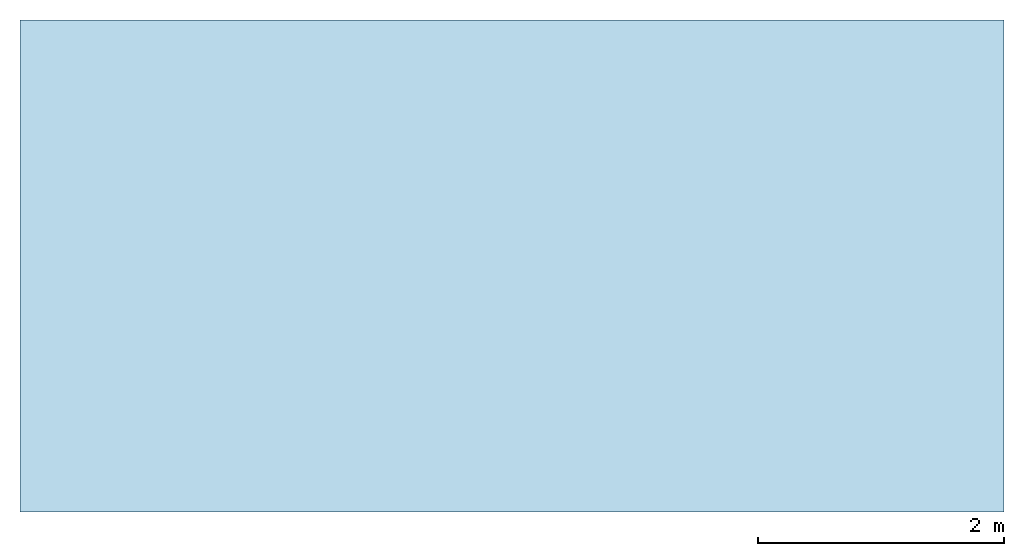
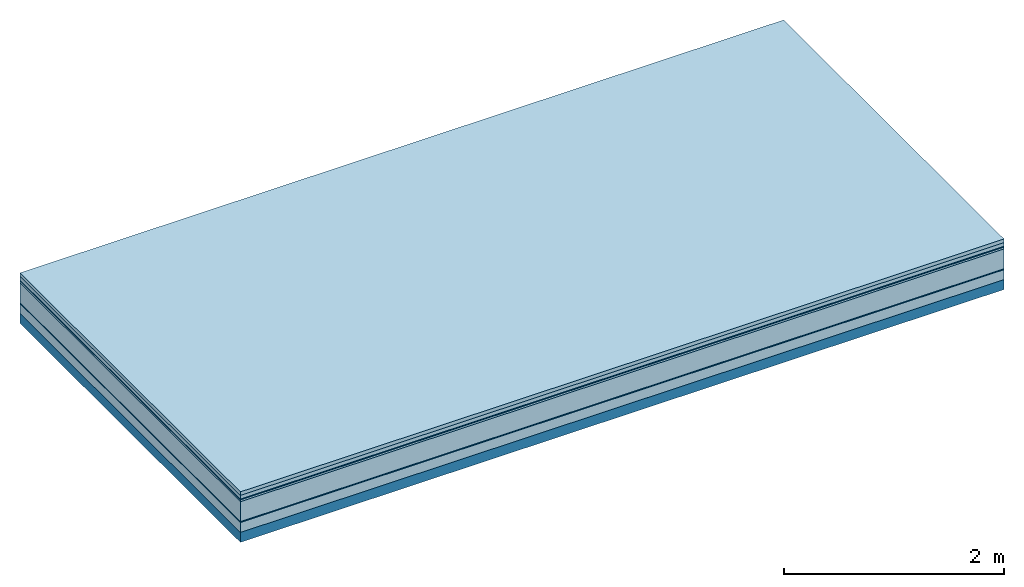
# One storey: 7 plates, 1 member, 1 element without a shape of its own.
"""IFC4 building model written with IfcOpenShell, lengths in metres."""

from ifc_helpers import new_model, si_unit, derived_unit, direction, frame, frame_2d, origin, origin_with_axes, place, context, project, spatial, rectangle, extrude, material, layer, layer_set, type_object, element, aggregate, save


model = new_model("IFC4")

# Units and contexts
plan_context = context("Plan", 3, precision=1e-05, world=origin(), true_north=direction((0.0, 1.0)))
model_context = context("Model", 3, precision=1e-05, world=origin(), true_north=direction((0.0, 1.0)))
ifc_project = project(units=[si_unit("LENGTHUNIT", "METRE"), derived_unit("SOUNDPRESSUREUNIT", [(si_unit("PRESSUREUNIT", "PASCAL", prefix="MICRO"), 0)]), si_unit("ENERGYUNIT", "JOULE", prefix="MEGA"), si_unit("MASSUNIT", "GRAM", prefix="KILO"), derived_unit("THERMALTRANSMITTANCEUNIT", [(si_unit("POWERUNIT", "WATT"), 1), (si_unit("AREAUNIT", "SQUARE_METRE"), -1), (si_unit("THERMODYNAMICTEMPERATUREUNIT", "KELVIN"), -1)]), derived_unit("AREADENSITYUNIT", [(si_unit("MASSUNIT", "GRAM", prefix="KILO"), 1), (si_unit("AREAUNIT", "SQUARE_METRE"), -1)]), derived_unit("USERDEFINED", [(si_unit("ENERGYUNIT", "JOULE", prefix="MEGA"), 1), (si_unit("AREAUNIT", "SQUARE_METRE"), -1)])], contexts=[plan_context, model_context])

# Site, building, storey
site = spatial("IfcSite", under=ifc_project)
building_placement = place(None, origin())
building = spatial("IfcBuilding", under=site, at=building_placement)
storey_placement = place(building_placement, origin())
storey = spatial("IfcBuildingStorey", under=building, at=storey_placement)

# Slab, member, plates
ifc_material_1 = material(Name="Garden plates", Category="02.007")
ifc_layer_1 = layer(ifc_material_1, 0.04, Name="Use and protection layer 3")
ifc_material_2 = material(Name="Gravel 8-16mm", Category="03.011")
ifc_layer_2 = layer(ifc_material_2, 0.04, Name="Use and protection layer 2")
ifc_material_3 = material(Name="Protective layer", Category="09.007")
ifc_layer_3 = layer(ifc_material_3, 0.01, Name="Use and protection layer 1")
ifc_material_4 = material(Name="Bituminous", Category="09.003")
ifc_layer_4 = layer(ifc_material_4, 0.02, Name="Seal")
ifc_material_5 = material(Name="Mineral wool", Category="10.008")
ifc_layer_5 = layer(ifc_material_5, 0.22, Name="Exterior insulation layer 1")
ifc_material_6 = material(Name="Vapor-permeable barrier", Category="09.006")
ifc_layer_6 = layer(ifc_material_6, 0.01, Name="layer / temporary roof")
ifc_material_7 = material(Category="01.002")
ifc_layer_7 = layer(ifc_material_7, 0.11, Name="above 1st layer")
ifc_material_8 = material(Name="Rigid, of the art")
ifc_layer_8 = layer(ifc_material_8, 0.0, Name="Bond")
ifc_layer_9 = layer(None, 0.11, Name="Support")
ifc_layer_set = layer_set([ifc_layer_1, ifc_layer_2, ifc_layer_3, ifc_layer_4, ifc_layer_5, ifc_layer_6, ifc_layer_7, ifc_layer_8, ifc_layer_9])
slab_type = type_object("IfcSlabType", Name="F0084", PredefinedType="NOTDEFINED", material=ifc_layer_set)
slab_placement = place(None, frame((0.0, 0.0, 0.0), z_axis=(0.0, 0.0, -1.0), x_axis=(1.0, 0.0, 0.0)))
slab = element("IfcSlab", 1, at=slab_placement, inside=storey, type_object=slab_type, material=ifc_layer_set, Name="Slab #1")
ifc_material_9 = material(Name="Solid timber panel")
member_placement = place(slab_placement, origin())
member = element("IfcMember", 2, at=member_placement, material=ifc_material_9, Name="Support", context=plan_context, shape_type="SweptSolid", body=[
    extrude(rectangle(XDim=1.0, YDim=0.11, at=frame_2d((0.5, 0.055), x_axis=(1.0, 0.0))), frame((0.0, 4.0, 0.45), z_axis=(0.0, -1.0, 0.0), x_axis=(1.0, 0.0, 0.0)), (0.0, 0.0, 1.0), 4.0),
    extrude(rectangle(XDim=1.0, YDim=0.11, at=frame_2d((0.5, 0.055), x_axis=(1.0, 0.0))), frame((1.0, 4.0, 0.45), z_axis=(0.0, -1.0, 0.0), x_axis=(1.0, 0.0, 0.0)), (0.0, 0.0, 1.0), 4.0),
    extrude(rectangle(XDim=1.0, YDim=0.11, at=frame_2d((0.5, 0.055), x_axis=(1.0, 0.0))), frame((2.0, 4.0, 0.45), z_axis=(0.0, -1.0, 0.0), x_axis=(1.0, 0.0, 0.0)), (0.0, 0.0, 1.0), 4.0),
    extrude(rectangle(XDim=1.0, YDim=0.11, at=frame_2d((0.5, 0.055), x_axis=(1.0, 0.0))), frame((3.0, 4.0, 0.45), z_axis=(0.0, -1.0, 0.0), x_axis=(1.0, 0.0, 0.0)), (0.0, 0.0, 1.0), 4.0),
    extrude(rectangle(XDim=1.0, YDim=0.11, at=frame_2d((0.5, 0.055), x_axis=(1.0, 0.0))), frame((4.0, 4.0, 0.45), z_axis=(0.0, -1.0, 0.0), x_axis=(1.0, 0.0, 0.0)), (0.0, 0.0, 1.0), 4.0),
    extrude(rectangle(XDim=1.0, YDim=0.11, at=frame_2d((0.5, 0.055), x_axis=(1.0, 0.0))), frame((5.0, 4.0, 0.45), z_axis=(0.0, -1.0, 0.0), x_axis=(1.0, 0.0, 0.0)), (0.0, 0.0, 1.0), 4.0),
    extrude(rectangle(XDim=1.0, YDim=0.11, at=frame_2d((0.5, 0.055), x_axis=(1.0, 0.0))), frame((6.0, 4.0, 0.45), z_axis=(0.0, -1.0, 0.0), x_axis=(1.0, 0.0, 0.0)), (0.0, 0.0, 1.0), 4.0),
    extrude(rectangle(XDim=1.0, YDim=0.11, at=frame_2d((0.5, 0.055), x_axis=(1.0, 0.0))), frame((7.0, 4.0, 0.45), z_axis=(0.0, -1.0, 0.0), x_axis=(1.0, 0.0, 0.0)), (0.0, 0.0, 1.0), 4.0),
])
plate_1_placement = place(slab_placement, origin())
plate_1 = element("IfcPlate", 3, at=plate_1_placement, material=ifc_material_1, Name="Use and protection layer 3", context=plan_context, shape_type="SweptSolid", body=[
    extrude(rectangle(XDim=8.0, YDim=4.0, at=frame_2d((4.0, 2.0), x_axis=(1.0, 0.0))), origin_with_axes(), (0.0, 0.0, 1.0), 0.04),
])
plate_2_placement = place(slab_placement, origin())
plate_2 = element("IfcPlate", 4, at=plate_2_placement, material=ifc_material_2, Name="Use and protection layer 2", context=plan_context, shape_type="SweptSolid", body=[
    extrude(rectangle(XDim=8.0, YDim=4.0, at=frame_2d((4.0, 2.0), x_axis=(1.0, 0.0))), frame((0.0, 0.0, 0.04), z_axis=(0.0, 0.0, 1.0), x_axis=(1.0, 0.0, 0.0)), (0.0, 0.0, 1.0), 0.04),
])
plate_3_placement = place(slab_placement, origin())
plate_3 = element("IfcPlate", 5, at=plate_3_placement, material=ifc_material_3, Name="Use and protection layer 1", context=plan_context, shape_type="SweptSolid", body=[
    extrude(rectangle(XDim=8.0, YDim=4.0, at=frame_2d((4.0, 2.0), x_axis=(1.0, 0.0))), frame((0.0, 0.0, 0.08), z_axis=(0.0, 0.0, 1.0), x_axis=(1.0, 0.0, 0.0)), (0.0, 0.0, 1.0), 0.01),
])
plate_4_placement = place(slab_placement, origin())
plate_4 = element("IfcPlate", 6, at=plate_4_placement, material=ifc_material_4, Name="Seal", context=plan_context, shape_type="SweptSolid", body=[
    extrude(rectangle(XDim=8.0, YDim=4.0, at=frame_2d((4.0, 2.0), x_axis=(1.0, 0.0))), frame((0.0, 0.0, 0.09), z_axis=(0.0, 0.0, 1.0), x_axis=(1.0, 0.0, 0.0)), (0.0, 0.0, 1.0), 0.02),
])
plate_5_placement = place(slab_placement, origin())
plate_5 = element("IfcPlate", 7, at=plate_5_placement, material=ifc_material_5, Name="Exterior insulation layer 1", context=plan_context, shape_type="SweptSolid", body=[
    extrude(rectangle(XDim=8.0, YDim=4.0, at=frame_2d((4.0, 2.0), x_axis=(1.0, 0.0))), frame((0.0, 0.0, 0.11), z_axis=(0.0, 0.0, 1.0), x_axis=(1.0, 0.0, 0.0)), (0.0, 0.0, 1.0), 0.22),
])
plate_6_placement = place(slab_placement, origin())
plate_6 = element("IfcPlate", 8, at=plate_6_placement, material=ifc_material_6, Name="layer / temporary roof", context=plan_context, shape_type="SweptSolid", body=[
    extrude(rectangle(XDim=8.0, YDim=4.0, at=frame_2d((4.0, 2.0), x_axis=(1.0, 0.0))), frame((0.0, 0.0, 0.33), z_axis=(0.0, 0.0, 1.0), x_axis=(1.0, 0.0, 0.0)), (0.0, 0.0, 1.0), 0.01),
])
plate_7_placement = place(slab_placement, origin())
plate_7 = element("IfcPlate", 9, at=plate_7_placement, material=ifc_material_7, Name="above 1st layer", context=plan_context, shape_type="SweptSolid", body=[
    extrude(rectangle(XDim=8.0, YDim=4.0, at=frame_2d((4.0, 2.0), x_axis=(1.0, 0.0))), frame((0.0, 0.0, 0.34), z_axis=(0.0, 0.0, 1.0), x_axis=(1.0, 0.0, 0.0)), (0.0, 0.0, 1.0), 0.11),
])
aggregate(slab, [plate_1, plate_2, plate_3, plate_4, plate_5, plate_6, plate_7, member])

save(model, "model.ifc")
